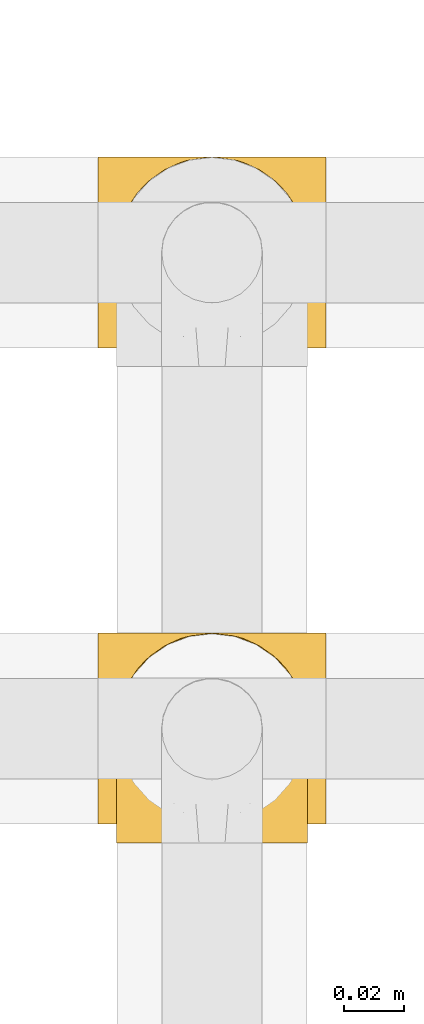
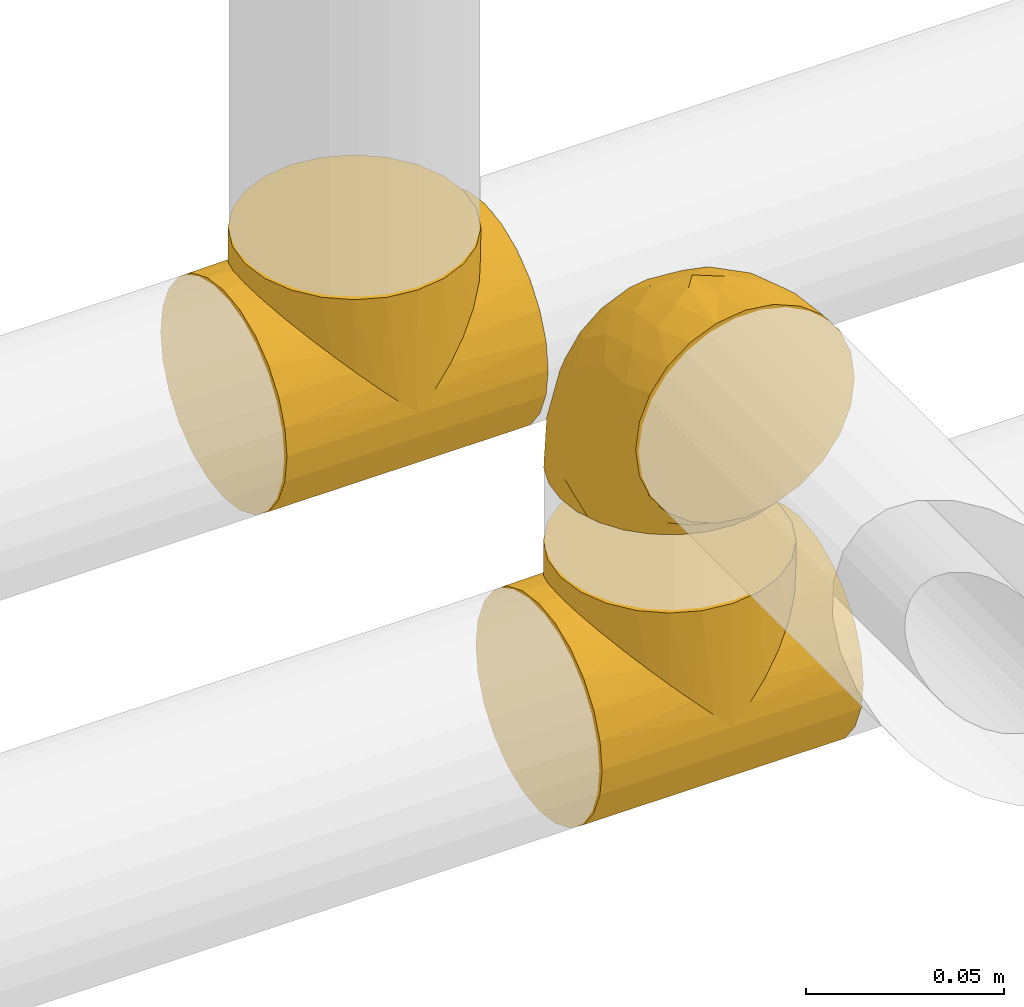
# One storey, part 12 of 39: 3 coverings.
"""IFC2X3 building model written with IfcOpenShell, lengths in millimetres."""

from ifc_helpers import new_model, entity, si_unit, converted_unit, derived_unit, direction, frame, origin, place, context, subcontext, project, spatial, faceted_brep, element, save


model = new_model("IFC2X3")

# Units and contexts
model_context = context("Model", 3, precision=0.01, world=origin(), true_north=direction((6.12303176911189e-17, 1.0)))
body_context = subcontext(model_context, "Body", "Model", "MODEL_VIEW")
ifc_project = project(units=[si_unit("LENGTHUNIT", "METRE", prefix="MILLI"), si_unit("AREAUNIT", "SQUARE_METRE"), si_unit("VOLUMEUNIT", "CUBIC_METRE"), converted_unit("PLANEANGLEUNIT", "DEGREE", entity("IfcRatioMeasure", 0.0174532925199433), si_unit("PLANEANGLEUNIT", "RADIAN"), dimensions=[0, 0, 0, 0, 0, 0, 0]), si_unit("MASSUNIT", "GRAM", prefix="KILO"), derived_unit("MASSDENSITYUNIT", [(si_unit("MASSUNIT", "GRAM", prefix="KILO"), 1), (si_unit("LENGTHUNIT", "METRE"), -3)]), derived_unit("MOMENTOFINERTIAUNIT", [(si_unit("LENGTHUNIT", "METRE"), 4)]), si_unit("TIMEUNIT", "SECOND"), si_unit("FREQUENCYUNIT", "HERTZ"), si_unit("THERMODYNAMICTEMPERATUREUNIT", "DEGREE_CELSIUS"), derived_unit("THERMALTRANSMITTANCEUNIT", [(si_unit("MASSUNIT", "GRAM", prefix="KILO"), 1), (si_unit("THERMODYNAMICTEMPERATUREUNIT", "KELVIN"), -1), (si_unit("TIMEUNIT", "SECOND"), -3)]), derived_unit("VOLUMETRICFLOWRATEUNIT", [(si_unit("LENGTHUNIT", "METRE"), 3), (si_unit("TIMEUNIT", "SECOND"), -1)]), derived_unit("MASSFLOWRATEUNIT", [(si_unit("MASSUNIT", "GRAM", prefix="KILO"), 1), (si_unit("TIMEUNIT", "SECOND"), -1)]), derived_unit("ROTATIONALFREQUENCYUNIT", [(si_unit("TIMEUNIT", "SECOND"), -1)]), si_unit("ELECTRICCURRENTUNIT", "AMPERE"), si_unit("ELECTRICVOLTAGEUNIT", "VOLT"), si_unit("POWERUNIT", "WATT"), si_unit("FORCEUNIT", "NEWTON", prefix="KILO"), si_unit("ILLUMINANCEUNIT", "LUX"), si_unit("LUMINOUSFLUXUNIT", "LUMEN"), si_unit("LUMINOUSINTENSITYUNIT", "CANDELA"), derived_unit("USERDEFINED", [(si_unit("MASSUNIT", "GRAM", prefix="KILO"), -1), (si_unit("LENGTHUNIT", "METRE"), -2), (si_unit("TIMEUNIT", "SECOND"), 3), (si_unit("LUMINOUSFLUXUNIT", "LUMEN"), 1)]), derived_unit("LINEARVELOCITYUNIT", [(si_unit("LENGTHUNIT", "METRE"), 1), (si_unit("TIMEUNIT", "SECOND"), -1)]), si_unit("PRESSUREUNIT", "PASCAL"), derived_unit("USERDEFINED", [(si_unit("LENGTHUNIT", "METRE"), -2), (si_unit("MASSUNIT", "GRAM", prefix="KILO"), 1), (si_unit("TIMEUNIT", "SECOND"), -2)]), derived_unit("LINEARFORCEUNIT", [(si_unit("MASSUNIT", "GRAM", prefix="KILO"), 1), (si_unit("LENGTHUNIT", "METRE"), 1), (si_unit("TIMEUNIT", "SECOND"), -2), (si_unit("LENGTHUNIT", "METRE"), -1)]), derived_unit("PLANARFORCEUNIT", [(si_unit("MASSUNIT", "GRAM", prefix="KILO"), 1), (si_unit("LENGTHUNIT", "METRE"), 1), (si_unit("TIMEUNIT", "SECOND"), -2), (si_unit("LENGTHUNIT", "METRE"), -2)])], contexts=[model_context])

# Site, building, storey
site_placement = place(None, origin())
site = spatial("IfcSite", under=ifc_project, at=site_placement, CompositionType="ELEMENT")
building_placement = place(site_placement, origin())
building = spatial("IfcBuilding", under=site, at=building_placement, CompositionType="ELEMENT")
storey_placement = place(building_placement, frame((0.0, 0.0, 24000.0)))
storey = spatial("IfcBuildingStorey", under=building, at=storey_placement, Name="07", CompositionType="ELEMENT", Elevation=24000.0)

# Coverings
covering_1_placement = place(storey_placement, frame((29497.73, 8217.67, 3166.55)))
element("IfcCovering", 1, at=covering_1_placement, inside=storey, Name=":ADSK_", ObjectType=":ADSK_", PredefinedType="INSULATION", context=body_context, shape_type="Brep", body=[
    faceted_brep([(0.0, 29.33, 64.75), (0.0, 25.21, 64.2), (7.04, 25.97, 64.39), (0.0, 14.24, 58.47), (0.0, 10.95, 55.93), (13.1, 13.6, 58.31), (0.0, 17.54, 61.0), (0.0, 21.37, 62.6), (9.51, 19.23, 61.92), (8.27, 22.6, 63.15), (0.0, 33.45, 65.3), (6.6, 29.71, 64.84), (6.15, 33.45, 65.3), (69.85, 33.45, 65.3), (69.4, 29.71, 64.84), (76.0, 33.45, 65.3), (17.44, 9.14, 53.96), (22.26, 5.79, 49.14), (0.0, 5.9, 49.33), (27.37, 3.46, 44.03), (0.0, 2.73, 41.64), (32.65, 2.1, 38.75), (0.0, 1.65, 33.4), (38.0, 1.65, 33.4), (43.35, 2.1, 38.75), (76.0, 1.65, 33.4), (32.65, 64.89, 38.85), (0.0, 65.35, 33.49), (0.0, 64.26, 41.74), (0.0, 61.06, 49.41), (27.37, 63.51, 44.12), (17.45, 57.8, 54.04), (0.0, 55.99, 56.0), (0.0, 41.7, 64.22), (8.27, 44.3, 63.19), (0.0, 45.54, 62.64), (22.26, 61.17, 49.23), (38.0, 65.35, 33.49), (43.35, 64.89, 38.85), (76.0, 65.35, 33.49), (6.59, 37.19, 64.86), (0.0, 37.58, 64.76), (13.1, 53.33, 58.37), (0.0, 52.69, 58.53), (0.0, 49.39, 61.05), (7.04, 40.92, 64.42), (69.41, 37.19, 64.86), (9.5, 47.68, 61.97), (76.0, 2.75, 25.15), (76.0, 5.95, 17.48), (76.0, 11.02, 10.89), (76.0, 17.62, 5.84), (76.0, 25.31, 2.67), (76.0, 33.55, 1.6), (76.0, 41.79, 2.69), (76.0, 49.47, 5.89), (76.0, 56.06, 10.96), (76.0, 61.11, 17.56), (76.0, 64.28, 25.25), (76.0, 64.26, 41.74), (76.0, 61.06, 49.41), (76.0, 55.99, 56.0), (76.0, 52.69, 58.53), (76.0, 49.39, 61.05), (76.0, 45.54, 62.64), (76.0, 41.7, 64.22), (76.0, 37.58, 64.76), (76.0, 29.33, 64.75), (76.0, 25.21, 64.2), (76.0, 21.37, 62.6), (76.0, 17.54, 61.0), (76.0, 14.24, 58.47), (76.0, 10.95, 55.93), (76.0, 5.9, 49.33), (76.0, 2.73, 41.64), (0.0, 64.28, 25.25), (0.0, 61.11, 17.56), (0.0, 56.06, 10.96), (0.0, 49.47, 5.89), (0.0, 41.79, 2.69), (0.0, 33.55, 1.6), (0.0, 25.31, 2.67), (0.0, 17.62, 5.84), (0.0, 11.02, 10.89), (0.0, 5.95, 17.48), (0.0, 2.75, 25.15), (48.63, 63.51, 44.12), (53.74, 61.17, 49.23), (58.55, 57.8, 54.04), (62.9, 53.33, 58.37), (66.5, 47.68, 61.97), (67.73, 44.3, 63.19), (68.96, 40.92, 64.42), (68.96, 25.97, 64.39), (62.9, 13.6, 58.31), (66.49, 19.23, 61.92), (67.73, 22.6, 63.15), (58.56, 9.14, 53.96), (53.74, 5.79, 49.14), (48.63, 3.46, 44.03), (38.0, 65.3, 71.49), (29.76, 64.21, 71.49), (22.07, 61.03, 71.49), (15.48, 55.97, 71.48), (12.95, 52.67, 71.47), (10.42, 49.37, 71.47), (8.83, 45.53, 71.46), (7.24, 41.69, 71.46), (6.69, 37.57, 71.45), (6.15, 33.45, 71.45), (6.69, 29.32, 71.44), (7.24, 25.2, 71.43), (8.83, 21.36, 71.43), (10.42, 17.52, 71.42), (12.95, 14.22, 71.42), (15.48, 10.92, 71.41), (22.07, 5.86, 71.4), (29.76, 2.68, 71.4), (38.0, 1.6, 71.4), (46.24, 2.68, 71.4), (53.92, 5.86, 71.4), (60.52, 10.92, 71.41), (63.05, 14.22, 71.42), (65.58, 17.52, 71.42), (67.17, 21.36, 71.43), (68.76, 25.2, 71.43), (69.31, 29.32, 71.44), (69.85, 33.45, 71.45), (69.31, 37.57, 71.45), (68.76, 41.69, 71.46), (67.17, 45.53, 71.46), (65.58, 49.37, 71.47), (63.05, 52.67, 71.47), (60.52, 55.97, 71.48), (53.92, 61.03, 71.49), (46.24, 64.21, 71.49)], [[[0, 1, 2]], [[3, 4, 5, 6]], [[7, 8, 9]], [[7, 6, 8]], [[10, 11, 12]], [[13, 14, 15]], [[10, 0, 11]], [[1, 9, 2]], [[5, 8, 6]], [[7, 9, 1]], [[4, 16, 5]], [[17, 16, 18]], [[18, 16, 4]], [[19, 18, 20]], [[21, 20, 22]], [[19, 17, 18]], [[23, 21, 22]], [[24, 23, 25]], [[19, 20, 21]], [[0, 2, 11]], [[26, 27, 28]], [[28, 29, 30]], [[31, 29, 32]], [[33, 34, 35]], [[31, 36, 29]], [[26, 37, 27]], [[37, 38, 39]], [[36, 30, 29]], [[26, 28, 30]], [[10, 40, 41]], [[42, 32, 43, 44]], [[33, 45, 34]], [[10, 12, 40]], [[15, 46, 13]], [[47, 44, 35]], [[47, 42, 44]], [[45, 41, 40]], [[35, 34, 47]], [[45, 33, 41]], [[32, 42, 31]], [[48, 49, 50, 51, 52, 53, 54, 55, 56, 57, 58, 39, 59, 60, 61, 62, 63, 64, 65, 66, 15, 67, 68, 69, 70, 71, 72, 73, 74, 25]], [[27, 75, 76, 77, 78, 79, 80, 81, 82, 83, 84, 85, 22, 20, 18, 4, 3, 6, 7, 1, 0, 10, 41, 33, 35, 44, 43, 32, 29, 28]], [[78, 77, 56, 55]], [[53, 80, 79, 54]], [[79, 78, 55, 54]], [[57, 76, 75, 58]], [[27, 37, 39, 58, 75]], [[56, 77, 76, 57]], [[86, 87, 60]], [[38, 86, 59]], [[39, 38, 59]], [[60, 88, 61]], [[60, 59, 86]], [[88, 60, 87]], [[89, 63, 62, 61]], [[89, 90, 63]], [[65, 91, 92]], [[15, 66, 46]], [[66, 92, 46]], [[65, 64, 91]], [[64, 90, 91]], [[64, 63, 90]], [[66, 65, 92]], [[89, 61, 88]], [[93, 67, 14]], [[94, 72, 71, 70]], [[95, 94, 70]], [[95, 70, 69]], [[68, 96, 69]], [[95, 69, 96]], [[15, 14, 67]], [[93, 68, 67]], [[96, 68, 93]], [[94, 97, 72]], [[98, 99, 73]], [[99, 24, 74]], [[97, 73, 72]], [[97, 98, 73]], [[73, 99, 74]], [[24, 25, 74]], [[23, 22, 85, 48, 25]], [[48, 85, 84, 49]], [[84, 83, 50, 49]], [[50, 83, 82, 51]], [[51, 82, 81, 52]], [[52, 81, 80, 53]], [[100, 101, 102, 103, 104, 105, 106, 107, 108, 109, 110, 111, 112, 113, 114, 115, 116, 117, 118, 119, 120, 121, 122, 123, 124, 125, 126, 127, 128, 129, 130, 131, 132, 133, 134, 135]], [[45, 108, 107]], [[106, 105, 47]], [[108, 45, 40]], [[103, 42, 105, 104]], [[109, 40, 12]], [[109, 108, 40]], [[107, 34, 45]], [[42, 47, 105]], [[106, 34, 107]], [[103, 31, 42]], [[36, 31, 102]], [[102, 31, 103]], [[30, 102, 101]], [[26, 101, 100]], [[30, 36, 102]], [[37, 26, 100]], [[30, 101, 26]], [[106, 47, 34]], [[38, 100, 135]], [[135, 134, 86]], [[88, 134, 133]], [[129, 91, 130]], [[88, 87, 134]], [[38, 37, 100]], [[87, 86, 134]], [[38, 135, 86]], [[127, 46, 128]], [[89, 133, 132, 131]], [[129, 92, 91]], [[127, 13, 46]], [[90, 131, 130]], [[90, 89, 131]], [[92, 128, 46]], [[130, 91, 90]], [[92, 129, 128]], [[133, 89, 88]], [[126, 125, 93]], [[122, 121, 94, 123]], [[124, 95, 96]], [[124, 123, 95]], [[127, 14, 13]], [[127, 126, 14]], [[125, 96, 93]], [[94, 95, 123]], [[124, 96, 125]], [[121, 97, 94]], [[98, 97, 120]], [[120, 97, 121]], [[99, 120, 119]], [[24, 119, 118]], [[99, 98, 120]], [[23, 24, 118]], [[99, 119, 24]], [[126, 93, 14]], [[21, 118, 117]], [[117, 116, 19]], [[16, 116, 115]], [[16, 17, 116]], [[21, 23, 118]], [[109, 11, 110]], [[17, 19, 116]], [[21, 117, 19]], [[111, 9, 112]], [[5, 115, 114, 113]], [[111, 2, 9]], [[109, 12, 11]], [[8, 113, 112]], [[8, 5, 113]], [[2, 110, 11]], [[112, 9, 8]], [[2, 111, 110]], [[115, 5, 16]]]),
])
covering_2_placement = place(storey_placement, frame((29502.28, 8211.48, 3260.41)))
element("IfcCovering", 2, at=covering_2_placement, inside=storey, Name=":ADSK_", ObjectType=":ADSK_", PredefinedType="INSULATION", context=body_context, shape_type="Brep", body=[
    faceted_brep([(1.6, 39.6, 1.64), (2.39, 46.69, 1.66), (4.75, 53.42, 1.67), (8.55, 59.46, 1.68), (13.59, 64.5, 1.68), (19.63, 68.29, 1.69), (26.36, 70.65, 1.69), (33.45, 71.45, 1.69), (40.54, 70.65, 1.69), (47.27, 68.29, 1.69), (53.31, 64.49, 1.68), (58.35, 59.45, 1.68), (62.14, 53.41, 1.67), (64.5, 46.68, 1.66), (65.3, 39.6, 1.64), (64.86, 35.69, 1.64), (64.5, 32.5, 1.63), (63.32, 29.14, 1.63), (62.14, 25.77, 1.62), (58.34, 19.73, 1.61), (53.3, 14.69, 1.61), (47.26, 10.9, 1.6), (40.53, 8.54, 1.6), (33.45, 7.75, 1.6), (26.35, 8.54, 1.6), (19.62, 10.9, 1.6), (13.58, 14.7, 1.61), (8.54, 19.74, 1.61), (4.75, 25.78, 1.62), (3.57, 29.15, 1.63), (2.39, 32.51, 1.63), (2.03, 35.69, 1.64), (1.82, 37.64, 1.64), (61.03, 1.6, 23.66), (62.62, 1.6, 27.5), (64.21, 1.6, 31.34), (64.78, 1.6, 35.66), (65.04, 1.6, 37.62), (65.3, 1.6, 39.59), (64.21, 1.6, 47.83), (61.03, 1.6, 55.51), (55.97, 1.6, 62.11), (49.37, 1.6, 67.17), (41.69, 1.6, 70.35), (33.45, 1.6, 71.44), (25.2, 1.6, 70.35), (17.52, 1.6, 67.17), (10.92, 1.6, 62.11), (5.86, 1.6, 55.51), (2.68, 1.6, 47.83), (1.6, 1.6, 39.59), (2.11, 1.6, 35.66), (2.68, 1.6, 31.34), (4.27, 1.6, 27.5), (5.86, 1.6, 23.66), (8.39, 1.6, 20.36), (10.92, 1.6, 17.06), (17.52, 1.6, 12.0), (25.2, 1.6, 8.82), (33.45, 1.6, 7.74), (41.69, 1.6, 8.82), (49.37, 1.6, 12.0), (55.97, 1.6, 17.06), (58.5, 1.6, 20.36), (2.86, 35.53, 33.96), (1.6, 34.48, 20.62), (1.6, 31.01, 24.09), (1.6, 27.53, 27.56), (1.6, 24.05, 31.03), (1.6, 20.58, 34.5), (33.45, 14.95, 68.78), (10.75, 32.16, 53.61), (5.89, 25.1, 50.17), (9.64, 17.36, 58.61), (22.45, 17.86, 67.5), (16.55, 27.9, 61.03), (15.16, 13.84, 64.49), (12.49, 61.35, 18.07), (25.02, 34.88, 61.7), (18.63, 44.2, 52.25), (2.29, 43.54, 16.76), (6.1, 40.89, 39.11), (5.18, 48.33, 25.9), (2.43, 17.2, 44.06), (11.1, 44.63, 44.38), (26.19, 63.81, 31.45), (24.02, 68.07, 17.81), (19.02, 61.82, 29.54), (4.77, 12.14, 52.36), (1.6, 17.68, 35.28), (1.6, 14.78, 36.06), (1.6, 11.88, 36.83), (1.6, 8.99, 37.61), (1.6, 7.14, 38.1), (1.6, 5.29, 38.6), (7.57, 56.75, 14.14), (17.54, 66.06, 13.74), (33.45, 68.77, 15.04), (4.36, 51.19, 13.38), (1.6, 39.1, 3.49), (1.6, 38.6, 5.34), (1.6, 37.61, 9.03), (1.6, 36.83, 11.93), (1.6, 36.05, 14.83), (1.6, 35.26, 17.72), (9.85, 54.15, 29.26), (14.04, 58.61, 28.99), (28.37, 21.34, 68.16), (33.45, 66.1, 28.39), (25.75, 46.95, 53.46), (33.45, 39.62, 58.57), (33.45, 50.95, 51.02), (22.54, 55.29, 43.19), (15.6, 53.77, 39.31), (33.45, 28.3, 66.13), (28.45, 55.3, 45.63), (33.45, 58.52, 39.7), (9.47, 6.06, 18.03), (5.84, 8.03, 22.75), (5.67, 11.02, 21.91), (2.31, 8.18, 32.17), (2.89, 10.88, 29.07), (2.68, 24.33, 20.76), (22.04, 9.23, 4.75), (5.47, 22.31, 11.05), (5.05, 24.58, 6.82), (7.87, 20.16, 5.69), (25.26, 5.44, 7.7), (28.1, 7.56, 4.42), (33.45, 5.94, 5.94), (12.78, 6.34, 14.5), (2.62, 29.83, 11.66), (3.56, 28.11, 6.63), (11.92, 14.93, 7.34), (11.99, 11.11, 12.48), (17.45, 9.86, 7.99), (17.11, 6.35, 11.13), (7.66, 16.32, 14.07), (4.46, 22.19, 15.39), (7.62, 18.6, 10.84), (2.29, 32.33, 7.93), (3.16, 15.28, 26.17), (16.64, 11.69, 5.81), (12.24, 13.12, 9.94), (4.55, 14.99, 22.21), (7.85, 10.59, 18.37), (2.55, 27.2, 17.73), (7.38, 14.02, 16.86), (3.19, 27.12, 13.24), (4.97, 5.74, 24.94), (2.4, 19.84, 26.52), (2.0, 23.56, 26.12), (3.58, 19.07, 22.07), (4.67, 20.1, 17.41), (44.85, 9.22, 4.75), (50.24, 11.69, 5.81), (49.43, 9.85, 7.99), (59.22, 16.3, 14.08), (54.76, 13.15, 10.06), (59.54, 18.63, 11.55), (41.63, 5.44, 7.7), (64.6, 32.32, 7.93), (65.3, 37.61, 9.03), (65.3, 36.83, 11.93), (65.3, 36.05, 14.83), (38.79, 7.56, 4.42), (62.36, 14.82, 22.39), (64.44, 17.26, 27.96), (61.26, 10.57, 22.21), (65.3, 3.44, 39.09), (65.3, 11.88, 36.83), (65.3, 8.99, 37.61), (65.3, 5.29, 38.6), (59.93, 5.65, 21.48), (62.73, 6.88, 26.52), (60.5, 14.91, 18.08), (59.03, 10.58, 18.37), (56.0, 11.05, 13.88), (49.78, 6.35, 11.13), (64.58, 8.18, 32.17), (65.3, 20.58, 34.5), (65.3, 24.05, 31.03), (64.28, 29.85, 11.68), (59.0, 20.14, 5.68), (61.84, 24.57, 6.84), (65.3, 38.6, 5.34), (65.3, 38.1, 7.19), (54.96, 14.92, 7.35), (65.3, 14.78, 36.06), (64.66, 12.32, 31.37), (63.94, 23.9, 19.83), (65.3, 27.53, 27.56), (63.6, 19.3, 22.93), (63.33, 28.1, 6.63), (57.32, 5.99, 17.92), (54.13, 6.41, 14.5), (64.5, 28.11, 17.46), (61.41, 22.3, 11.05), (57.94, 18.2, 7.53), (65.3, 35.26, 17.72), (65.3, 34.48, 20.62), (63.42, 26.63, 12.34), (62.87, 10.31, 25.89), (64.69, 15.34, 30.26), (65.3, 17.68, 35.28), (65.3, 31.01, 24.09), (57.25, 17.36, 58.61), (62.54, 51.18, 13.37), (64.6, 43.53, 16.76), (64.46, 17.2, 44.06), (41.87, 34.88, 61.7), (44.44, 17.86, 67.5), (50.34, 27.9, 61.03), (61.0, 25.1, 50.17), (64.03, 35.54, 33.94), (60.79, 40.88, 39.1), (56.14, 32.16, 53.61), (38.52, 21.34, 68.16), (62.12, 12.13, 52.36), (51.73, 13.84, 64.49), (61.72, 48.32, 25.9), (59.33, 56.74, 14.14), (57.05, 54.14, 29.25), (47.88, 61.81, 29.55), (42.88, 68.06, 17.82), (40.71, 63.8, 31.46), (54.41, 61.34, 18.08), (41.13, 46.95, 53.46), (51.29, 53.76, 39.32), (52.85, 58.6, 29.0), (49.36, 66.05, 13.74), (48.26, 44.22, 52.23), (44.35, 55.29, 43.18), (55.8, 44.63, 44.38), (38.44, 55.3, 45.63)], [[[0, 1, 2, 3, 4, 5, 6, 7, 8, 9, 10, 11, 12, 13, 14, 15, 16, 17, 18, 19, 20, 21, 22, 23, 24, 25, 26, 27, 28, 29, 30, 31, 32]], [[33, 34, 35, 36, 37, 38, 39, 40, 41, 42, 43, 44, 45, 46, 47, 48, 49, 50, 51, 52, 53, 54, 55, 56, 57, 58, 59, 60, 61, 62, 63]], [[64, 65, 66, 67, 68, 69]], [[45, 44, 70]], [[71, 72, 73]], [[74, 75, 76]], [[77, 4, 3]], [[75, 78, 79]], [[0, 80, 1]], [[74, 46, 45]], [[64, 81, 82]], [[46, 76, 47]], [[83, 50, 49]], [[48, 47, 73]], [[71, 79, 84]], [[85, 86, 87]], [[49, 48, 88]], [[83, 69, 89, 90, 91, 92, 93, 94, 50]], [[95, 77, 3]], [[75, 74, 78]], [[87, 86, 96]], [[96, 86, 5]], [[96, 5, 4]], [[6, 86, 97]], [[83, 64, 69]], [[98, 80, 82]], [[73, 72, 88]], [[64, 80, 65]], [[7, 6, 97]], [[80, 0, 99, 100, 101, 102, 103, 104, 65]], [[77, 105, 106]], [[64, 82, 80]], [[70, 107, 45]], [[77, 95, 105]], [[82, 95, 98]], [[95, 3, 2]], [[74, 107, 78]], [[86, 6, 5]], [[72, 71, 81]], [[85, 108, 86]], [[76, 73, 47]], [[71, 84, 81]], [[109, 110, 111]], [[87, 112, 85]], [[79, 109, 112]], [[79, 112, 113]], [[88, 83, 49]], [[64, 83, 72]], [[4, 77, 96]], [[87, 96, 77]], [[98, 95, 2]], [[105, 95, 82]], [[81, 105, 82]], [[105, 84, 113]], [[2, 1, 98]], [[114, 107, 70]], [[80, 98, 1]], [[73, 75, 71]], [[79, 71, 75]], [[74, 76, 46]], [[73, 76, 75]], [[78, 107, 114]], [[45, 107, 74]], [[87, 113, 112]], [[115, 85, 112]], [[109, 79, 78]], [[113, 87, 106]], [[116, 115, 111]], [[116, 108, 85]], [[79, 113, 84]], [[109, 78, 110]], [[115, 109, 111]], [[85, 115, 116]], [[109, 115, 112]], [[72, 81, 64]], [[105, 81, 84]], [[73, 88, 48]], [[83, 88, 72]], [[86, 108, 97]], [[78, 114, 110]], [[113, 106, 105]], [[87, 77, 106]], [[117, 118, 119]], [[52, 120, 54, 53]], [[91, 120, 52]], [[91, 90, 120]], [[90, 121, 120]], [[122, 67, 66]], [[24, 123, 25]], [[124, 125, 126]], [[127, 59, 58]], [[128, 129, 127]], [[130, 57, 117]], [[131, 132, 125]], [[25, 133, 26]], [[128, 24, 23]], [[134, 135, 136]], [[137, 138, 139]], [[131, 103, 140]], [[28, 140, 29]], [[131, 65, 104, 103]], [[99, 0, 32, 31, 30, 101, 100]], [[141, 118, 121]], [[25, 123, 142]], [[52, 51, 50, 94, 93, 92, 91]], [[129, 128, 23]], [[117, 56, 118]], [[135, 134, 143]], [[139, 126, 133]], [[119, 144, 145]], [[127, 135, 123]], [[136, 58, 57]], [[101, 30, 29]], [[124, 138, 146]], [[140, 101, 29]], [[145, 147, 134]], [[140, 132, 131]], [[140, 103, 102, 101]], [[140, 28, 132]], [[146, 148, 124]], [[121, 69, 141]], [[55, 149, 118]], [[150, 151, 152]], [[147, 137, 134]], [[144, 150, 152]], [[152, 151, 122]], [[138, 122, 146]], [[59, 127, 129]], [[123, 24, 128]], [[58, 136, 127]], [[135, 127, 136]], [[121, 90, 89, 69]], [[120, 121, 149]], [[122, 66, 146]], [[153, 122, 138]], [[141, 69, 68]], [[127, 123, 128]], [[123, 135, 142]], [[143, 142, 135]], [[25, 142, 133]], [[66, 65, 146]], [[148, 65, 131]], [[28, 27, 132]], [[125, 132, 27]], [[126, 125, 27]], [[148, 125, 124]], [[27, 26, 126]], [[133, 126, 26]], [[139, 138, 124]], [[153, 138, 137]], [[126, 139, 124]], [[139, 133, 143]], [[147, 153, 137]], [[152, 122, 153]], [[134, 136, 130]], [[137, 139, 143]], [[144, 147, 145]], [[153, 147, 152]], [[141, 144, 119]], [[55, 54, 149]], [[65, 148, 146]], [[125, 148, 131]], [[137, 143, 134]], [[142, 143, 133]], [[130, 117, 145]], [[57, 56, 117]], [[134, 130, 145]], [[57, 130, 136]], [[150, 144, 141]], [[147, 144, 152]], [[141, 68, 150]], [[151, 68, 67]], [[68, 151, 150]], [[122, 151, 67]], [[117, 119, 145]], [[141, 119, 118]], [[118, 56, 55]], [[120, 149, 54]], [[118, 149, 121]], [[154, 155, 156]], [[157, 158, 159]], [[129, 160, 59]], [[161, 162, 163, 164]], [[165, 160, 129]], [[166, 167, 168]], [[169, 38, 37, 36, 35, 170, 171, 172]], [[63, 173, 174]], [[175, 176, 177]], [[60, 178, 61]], [[179, 35, 34, 33]], [[160, 60, 59]], [[180, 167, 181]], [[129, 23, 165]], [[182, 161, 164]], [[183, 19, 184]], [[15, 14, 185, 186, 162, 16]], [[187, 155, 21]], [[188, 179, 189]], [[187, 21, 20]], [[190, 191, 192]], [[182, 193, 161]], [[194, 176, 168]], [[176, 195, 177]], [[196, 190, 197]], [[17, 16, 162]], [[17, 161, 18]], [[20, 183, 198]], [[18, 161, 193]], [[156, 158, 177]], [[165, 23, 22]], [[194, 195, 176]], [[187, 159, 158]], [[179, 174, 189]], [[182, 164, 199, 200]], [[201, 200, 196]], [[193, 184, 19]], [[174, 173, 202]], [[203, 204, 189]], [[22, 154, 165]], [[160, 156, 178]], [[160, 165, 154]], [[178, 60, 160]], [[170, 35, 179]], [[188, 170, 179]], [[189, 174, 202]], [[174, 179, 33]], [[203, 189, 202]], [[181, 192, 191]], [[167, 180, 203]], [[192, 175, 190]], [[159, 190, 157]], [[21, 154, 22]], [[205, 196, 200]], [[205, 191, 190]], [[160, 154, 156]], [[21, 155, 154]], [[158, 155, 187]], [[202, 173, 168]], [[192, 181, 167]], [[190, 196, 205]], [[201, 196, 197]], [[184, 193, 182]], [[19, 18, 193]], [[201, 184, 182]], [[184, 201, 183]], [[197, 159, 198]], [[20, 19, 183]], [[162, 161, 17]], [[62, 173, 63]], [[174, 33, 63]], [[194, 173, 62]], [[173, 194, 168]], [[62, 61, 194]], [[195, 61, 178]], [[61, 195, 194]], [[177, 195, 178]], [[156, 177, 178]], [[175, 192, 166]], [[166, 168, 176]], [[167, 202, 168]], [[175, 166, 176]], [[167, 166, 192]], [[177, 157, 175]], [[190, 175, 157]], [[198, 159, 187]], [[190, 159, 197]], [[20, 198, 187]], [[197, 198, 183]], [[177, 158, 157]], [[155, 158, 156]], [[167, 203, 202]], [[201, 197, 183]], [[204, 203, 180]], [[204, 188, 189]], [[200, 201, 182]], [[41, 40, 206]], [[207, 208, 13]], [[209, 38, 169, 172, 171, 170, 188, 204, 180]], [[210, 211, 212]], [[213, 214, 215]], [[213, 216, 206]], [[43, 211, 217]], [[218, 40, 39]], [[217, 114, 70]], [[209, 214, 213]], [[206, 40, 218]], [[219, 42, 41]], [[217, 210, 114]], [[42, 219, 211]], [[215, 214, 220]], [[220, 221, 222]], [[200, 208, 214]], [[214, 208, 220]], [[14, 13, 208]], [[223, 224, 225]], [[10, 226, 11]], [[8, 97, 224]], [[110, 227, 111]], [[226, 221, 11]], [[228, 222, 229]], [[224, 230, 9]], [[8, 224, 9]], [[231, 232, 227]], [[225, 224, 108]], [[42, 211, 43]], [[231, 210, 212]], [[223, 226, 230]], [[38, 209, 39]], [[9, 230, 10]], [[214, 180, 181, 191, 205, 200]], [[221, 207, 12]], [[11, 221, 12]], [[208, 200, 199, 164, 163, 162, 186, 185, 14]], [[213, 215, 216]], [[219, 206, 212]], [[212, 216, 231]], [[227, 110, 210]], [[223, 232, 228]], [[223, 225, 232]], [[214, 209, 180]], [[218, 209, 213]], [[223, 230, 224]], [[226, 10, 230]], [[222, 221, 226]], [[207, 221, 220]], [[229, 222, 226]], [[215, 222, 233]], [[208, 207, 220]], [[44, 43, 70]], [[13, 12, 207]], [[231, 216, 233]], [[212, 206, 216]], [[206, 219, 41]], [[211, 219, 212]], [[43, 217, 70]], [[210, 217, 211]], [[234, 116, 111]], [[231, 233, 228]], [[225, 116, 234]], [[231, 227, 210]], [[225, 108, 116]], [[231, 228, 232]], [[222, 228, 233]], [[234, 227, 232]], [[226, 223, 229]], [[227, 234, 111]], [[225, 234, 232]], [[222, 215, 220]], [[215, 233, 216]], [[209, 218, 39]], [[206, 218, 213]], [[97, 8, 7]], [[97, 108, 224]], [[110, 114, 210]], [[228, 229, 223]]]),
])
covering_3_placement = place(storey_placement, frame((29497.73, 8376.51, 3166.55)))
element("IfcCovering", 3, at=covering_3_placement, inside=storey, Name=":ADSK_", ObjectType=":ADSK_", PredefinedType="INSULATION", context=body_context, shape_type="Brep", body=[
    faceted_brep([(43.35, 2.05, 38.8), (76.0, 1.6, 33.45), (76.0, 2.68, 41.69), (76.0, 5.86, 49.37), (48.63, 3.42, 44.08), (58.55, 9.11, 54.0), (76.0, 10.92, 55.97), (76.0, 25.2, 64.21), (67.73, 22.6, 63.18), (76.0, 21.36, 62.62), (53.74, 5.76, 49.18), (38.0, 1.6, 33.45), (32.65, 2.05, 38.8), (0.0, 1.6, 33.45), (76.0, 33.45, 65.3), (69.41, 29.71, 64.85), (76.0, 29.32, 64.75), (62.9, 13.58, 58.34), (76.0, 14.22, 58.5), (76.0, 17.52, 61.03), (68.96, 25.98, 64.41), (69.85, 33.45, 65.3), (0.0, 33.45, 65.3), (6.59, 29.71, 64.85), (6.15, 33.45, 65.3), (66.5, 19.22, 61.94), (76.0, 37.57, 64.75), (76.0, 41.69, 64.21), (68.96, 40.93, 64.4), (76.0, 52.67, 58.5), (76.0, 55.97, 55.97), (62.9, 53.31, 58.34), (76.0, 49.37, 61.03), (76.0, 45.53, 62.62), (66.49, 47.67, 61.94), (67.73, 44.3, 63.17), (69.4, 37.19, 64.85), (6.6, 37.19, 64.85), (58.56, 57.77, 54.0), (53.74, 61.13, 49.19), (76.0, 61.03, 49.37), (48.63, 63.47, 44.08), (76.0, 64.21, 41.69), (43.35, 64.84, 38.8), (76.0, 65.3, 33.45), (38.0, 65.3, 33.45), (32.65, 64.84, 38.8), (0.0, 65.3, 33.45), (0.0, 64.21, 25.2), (0.0, 61.03, 17.52), (0.0, 55.97, 10.92), (0.0, 49.37, 5.86), (0.0, 41.69, 2.68), (0.0, 33.45, 1.6), (0.0, 25.2, 2.68), (0.0, 17.52, 5.86), (0.0, 10.92, 10.92), (0.0, 5.86, 17.52), (0.0, 2.68, 25.2), (0.0, 2.68, 41.69), (0.0, 5.86, 49.37), (0.0, 10.92, 55.97), (0.0, 14.22, 58.5), (0.0, 17.52, 61.03), (0.0, 21.36, 62.62), (0.0, 25.2, 64.21), (0.0, 29.32, 64.75), (0.0, 37.57, 64.75), (0.0, 41.69, 64.21), (0.0, 45.53, 62.62), (0.0, 49.37, 61.03), (0.0, 52.67, 58.5), (0.0, 55.97, 55.97), (0.0, 61.03, 49.37), (0.0, 64.21, 41.69), (76.0, 2.68, 25.2), (76.0, 5.86, 17.52), (76.0, 10.92, 10.92), (76.0, 17.52, 5.86), (76.0, 25.2, 2.68), (76.0, 33.45, 1.6), (76.0, 41.69, 2.68), (76.0, 49.37, 5.86), (76.0, 55.97, 10.92), (76.0, 61.03, 17.52), (76.0, 64.21, 25.2), (27.37, 3.42, 44.08), (22.26, 5.76, 49.18), (17.45, 9.11, 54.0), (13.1, 13.58, 58.34), (9.5, 19.22, 61.94), (8.27, 22.6, 63.18), (7.04, 25.98, 64.41), (7.04, 40.93, 64.4), (13.1, 53.31, 58.34), (9.51, 47.67, 61.94), (8.27, 44.3, 63.17), (17.44, 57.77, 54.0), (22.26, 61.13, 49.19), (27.37, 63.47, 44.08), (38.0, 1.6, 71.45), (46.24, 2.68, 71.45), (53.93, 5.86, 71.45), (60.52, 10.92, 71.45), (63.05, 14.22, 71.45), (65.58, 17.52, 71.45), (67.17, 21.36, 71.45), (68.76, 25.2, 71.45), (69.31, 29.32, 71.45), (69.85, 33.45, 71.45), (69.31, 37.57, 71.45), (68.76, 41.69, 71.45), (67.17, 45.53, 71.45), (65.58, 49.37, 71.45), (63.05, 52.67, 71.45), (60.52, 55.97, 71.45), (53.93, 61.03, 71.45), (46.24, 64.21, 71.45), (38.0, 65.3, 71.45), (29.76, 64.21, 71.45), (22.08, 61.03, 71.45), (15.48, 55.97, 71.45), (12.95, 52.67, 71.45), (10.42, 49.37, 71.45), (8.83, 45.53, 71.45), (7.24, 41.69, 71.45), (6.69, 37.57, 71.45), (6.15, 33.45, 71.45), (6.69, 29.32, 71.45), (7.24, 25.2, 71.45), (8.83, 21.36, 71.45), (10.42, 17.52, 71.45), (12.95, 14.22, 71.45), (15.48, 10.92, 71.45), (22.08, 5.86, 71.45), (29.76, 2.68, 71.45)], [[[0, 1, 2]], [[2, 3, 4]], [[5, 3, 6]], [[7, 8, 9]], [[5, 10, 3]], [[0, 11, 1]], [[11, 12, 13]], [[10, 4, 3]], [[0, 2, 4]], [[14, 15, 16]], [[17, 6, 18, 19]], [[7, 20, 8]], [[14, 21, 15]], [[22, 23, 24]], [[25, 19, 9]], [[25, 17, 19]], [[20, 16, 15]], [[9, 8, 25]], [[20, 7, 16]], [[6, 17, 5]], [[26, 27, 28]], [[29, 30, 31, 32]], [[33, 34, 35]], [[33, 32, 34]], [[14, 36, 21]], [[24, 37, 22]], [[14, 26, 36]], [[27, 35, 28]], [[31, 34, 32]], [[33, 35, 27]], [[30, 38, 31]], [[39, 38, 40]], [[40, 38, 30]], [[41, 40, 42]], [[43, 42, 44]], [[41, 39, 40]], [[45, 43, 44]], [[46, 45, 47]], [[41, 42, 43]], [[26, 28, 36]], [[48, 49, 50, 51, 52, 53, 54, 55, 56, 57, 58, 13, 59, 60, 61, 62, 63, 64, 65, 66, 22, 67, 68, 69, 70, 71, 72, 73, 74, 47]], [[1, 75, 76, 77, 78, 79, 80, 81, 82, 83, 84, 85, 44, 42, 40, 30, 29, 32, 33, 27, 26, 14, 16, 7, 9, 19, 18, 6, 3, 2]], [[78, 77, 56, 55]], [[53, 80, 79, 54]], [[79, 78, 55, 54]], [[57, 76, 75, 58]], [[1, 11, 13, 58, 75]], [[56, 77, 76, 57]], [[86, 87, 60]], [[12, 86, 59]], [[13, 12, 59]], [[60, 88, 61]], [[60, 59, 86]], [[88, 60, 87]], [[89, 63, 62, 61]], [[89, 90, 63]], [[65, 91, 92]], [[22, 66, 23]], [[66, 92, 23]], [[65, 64, 91]], [[64, 90, 91]], [[64, 63, 90]], [[66, 65, 92]], [[89, 61, 88]], [[93, 67, 37]], [[94, 72, 71, 70]], [[95, 94, 70]], [[95, 70, 69]], [[68, 96, 69]], [[95, 69, 96]], [[22, 37, 67]], [[93, 68, 67]], [[96, 68, 93]], [[94, 97, 72]], [[98, 99, 73]], [[99, 46, 74]], [[97, 73, 72]], [[97, 98, 73]], [[73, 99, 74]], [[46, 47, 74]], [[45, 44, 85, 48, 47]], [[48, 85, 84, 49]], [[84, 83, 50, 49]], [[50, 83, 82, 51]], [[51, 82, 81, 52]], [[52, 81, 80, 53]], [[100, 101, 102, 103, 104, 105, 106, 107, 108, 109, 110, 111, 112, 113, 114, 115, 116, 117, 118, 119, 120, 121, 122, 123, 124, 125, 126, 127, 128, 129, 130, 131, 132, 133, 134, 135]], [[20, 108, 107]], [[106, 105, 25]], [[108, 20, 15]], [[103, 17, 105, 104]], [[109, 15, 21]], [[109, 108, 15]], [[107, 8, 20]], [[17, 25, 105]], [[106, 8, 107]], [[103, 5, 17]], [[10, 5, 102]], [[102, 5, 103]], [[4, 102, 101]], [[0, 101, 100]], [[4, 10, 102]], [[11, 0, 100]], [[4, 101, 0]], [[106, 25, 8]], [[12, 100, 135]], [[135, 134, 86]], [[88, 134, 133]], [[129, 91, 130]], [[88, 87, 134]], [[12, 11, 100]], [[87, 86, 134]], [[12, 135, 86]], [[127, 23, 128]], [[89, 133, 132, 131]], [[129, 92, 91]], [[127, 24, 23]], [[90, 131, 130]], [[90, 89, 131]], [[92, 128, 23]], [[130, 91, 90]], [[92, 129, 128]], [[133, 89, 88]], [[126, 125, 93]], [[122, 121, 94, 123]], [[124, 95, 96]], [[124, 123, 95]], [[127, 37, 24]], [[127, 126, 37]], [[125, 96, 93]], [[94, 95, 123]], [[124, 96, 125]], [[121, 97, 94]], [[98, 97, 120]], [[120, 97, 121]], [[99, 120, 119]], [[46, 119, 118]], [[99, 98, 120]], [[45, 46, 118]], [[99, 119, 46]], [[126, 93, 37]], [[43, 118, 117]], [[117, 116, 41]], [[38, 116, 115]], [[38, 39, 116]], [[43, 45, 118]], [[109, 36, 110]], [[39, 41, 116]], [[43, 117, 41]], [[111, 35, 112]], [[31, 115, 114, 113]], [[111, 28, 35]], [[109, 21, 36]], [[34, 113, 112]], [[34, 31, 113]], [[28, 110, 36]], [[112, 35, 34]], [[28, 111, 110]], [[115, 31, 38]]]),
])

save(model, "model.ifc")
